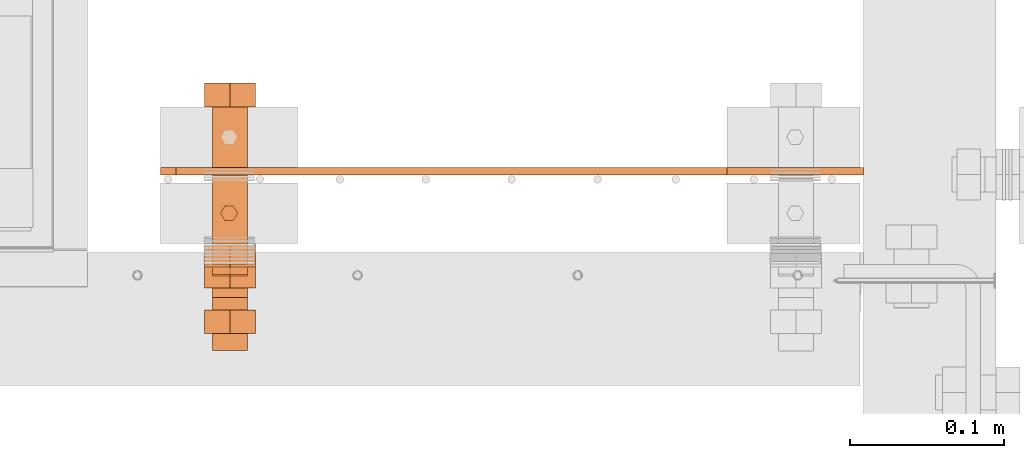
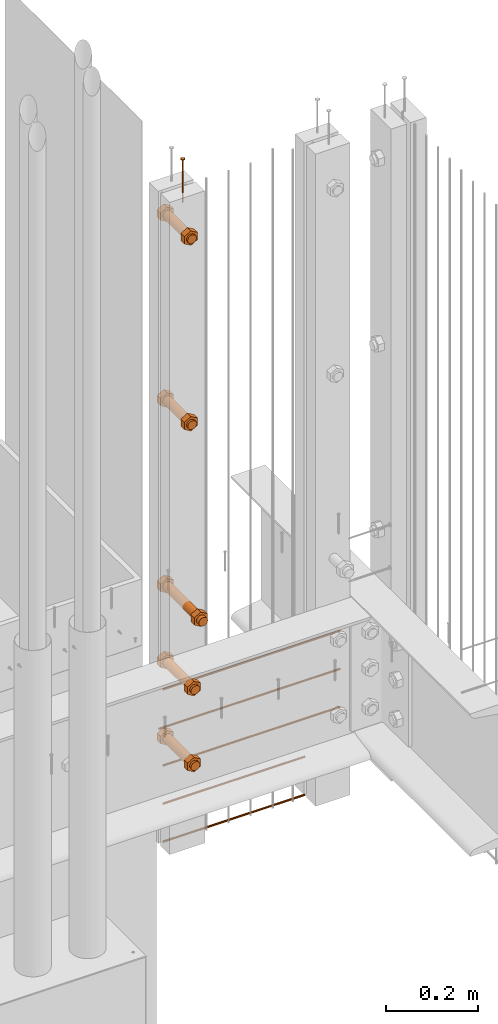
# One storey, part 20 of 44: 11 proxies.
"""IFC4 building model written with IfcOpenShell, lengths in feet."""

from ifc_helpers import new_model, entity, si_unit, converted_unit, derived_unit, direction, frame, frame_2d, origin, origin_2d_with_axis, place, context, subcontext, project, spatial, polyline, circle, outline, extrude, source, transform, mapped, material, type_object, type_shapes, element, save


model = new_model("IFC4")

# Units and contexts
model_context = context("Model", 3, precision=0.0001, world=origin(), true_north=direction((6.12303176911189e-17, 1.0)))
body_context = subcontext(model_context, "Body", "Model", "MODEL_VIEW")
ifc_project = project(units=[converted_unit("LENGTHUNIT", "FOOT", entity("IfcRatioMeasure", 0.3048), si_unit("LENGTHUNIT", "METRE"), dimensions=[1, 0, 0, 0, 0, 0, 0]), converted_unit("AREAUNIT", "SQUARE FOOT", entity("IfcRatioMeasure", 0.09290304), si_unit("AREAUNIT", "SQUARE_METRE"), dimensions=[2, 0, 0, 0, 0, 0, 0]), converted_unit("VOLUMEUNIT", "CUBIC FOOT", entity("IfcRatioMeasure", 0.028316846592), si_unit("VOLUMEUNIT", "CUBIC_METRE"), dimensions=[3, 0, 0, 0, 0, 0, 0]), converted_unit("PLANEANGLEUNIT", "DEGREE", entity("IfcRatioMeasure", 0.0174532925199433), si_unit("PLANEANGLEUNIT", "RADIAN"), dimensions=[0, 0, 0, 0, 0, 0, 0]), si_unit("MASSUNIT", "GRAM", prefix="KILO"), derived_unit("MASSDENSITYUNIT", [(si_unit("MASSUNIT", "GRAM", prefix="KILO"), 1), (si_unit("LENGTHUNIT", "METRE"), -3)]), derived_unit("MOMENTOFINERTIAUNIT", [(si_unit("LENGTHUNIT", "METRE"), 4)]), si_unit("TIMEUNIT", "SECOND"), si_unit("FREQUENCYUNIT", "HERTZ"), si_unit("THERMODYNAMICTEMPERATUREUNIT", "DEGREE_CELSIUS"), derived_unit("THERMALTRANSMITTANCEUNIT", [(si_unit("MASSUNIT", "GRAM", prefix="KILO"), 1), (si_unit("THERMODYNAMICTEMPERATUREUNIT", "KELVIN"), -1), (si_unit("TIMEUNIT", "SECOND"), -3)]), derived_unit("VOLUMETRICFLOWRATEUNIT", [(si_unit("LENGTHUNIT", "METRE"), 3), (si_unit("TIMEUNIT", "SECOND"), -1)]), si_unit("ELECTRICCURRENTUNIT", "AMPERE"), si_unit("ELECTRICVOLTAGEUNIT", "VOLT"), si_unit("POWERUNIT", "WATT"), si_unit("FORCEUNIT", "NEWTON"), si_unit("ILLUMINANCEUNIT", "LUX"), si_unit("LUMINOUSFLUXUNIT", "LUMEN"), si_unit("LUMINOUSINTENSITYUNIT", "CANDELA"), derived_unit("USERDEFINED", [(si_unit("MASSUNIT", "GRAM", prefix="KILO"), -1), (si_unit("LENGTHUNIT", "METRE"), -2), (si_unit("TIMEUNIT", "SECOND"), 3), (si_unit("LUMINOUSFLUXUNIT", "LUMEN"), 1)]), derived_unit("LINEARVELOCITYUNIT", [(si_unit("LENGTHUNIT", "METRE"), 1), (si_unit("TIMEUNIT", "SECOND"), -1)]), si_unit("PRESSUREUNIT", "PASCAL"), derived_unit("USERDEFINED", [(si_unit("LENGTHUNIT", "METRE"), -2), (si_unit("MASSUNIT", "GRAM", prefix="KILO"), 1), (si_unit("TIMEUNIT", "SECOND"), -2)]), derived_unit("LINEARFORCEUNIT", [(si_unit("MASSUNIT", "GRAM", prefix="KILO"), 1), (si_unit("LENGTHUNIT", "METRE"), 1), (si_unit("TIMEUNIT", "SECOND"), -2), (si_unit("LENGTHUNIT", "METRE"), -1)]), derived_unit("PLANARFORCEUNIT", [(si_unit("MASSUNIT", "GRAM", prefix="KILO"), 1), (si_unit("LENGTHUNIT", "METRE"), 1), (si_unit("TIMEUNIT", "SECOND"), -2), (si_unit("LENGTHUNIT", "METRE"), -2)])], contexts=[model_context])

# Site, building, storey
site_placement = place(None, origin())
site = spatial("IfcSite", under=ifc_project, at=site_placement, CompositionType="ELEMENT")
building_placement = place(site_placement, origin())
building = spatial("IfcBuilding", under=site, at=building_placement, CompositionType="ELEMENT")
storey_placement = place(building_placement, origin())
storey = spatial("IfcBuildingStorey", under=building, at=storey_placement, CompositionType="ELEMENT", Elevation=0.0)

# Proxies
ifc_material_1 = material(Category="Materials")
building_element_proxy_type_1 = type_object("IfcBuildingElementProxyType", Name="RAILING 29:RAILING 20", PredefinedType="NOTDEFINED", material=ifc_material_1)
shared_shape_1 = source(origin(), body_context, "Body", "SweptSolid", [
    extrude(circle(Radius=0.00833333333333333, at=origin_2d_with_axis()), frame((0.0, 0.0135671661283334, 0.0135671661283325), z_axis=(1.0, 0.0, 0.0), x_axis=(0.0, 1.0, 0.0)), (0.0, 0.0, 1.0), 1.17510891080246),
])
type_shapes(building_element_proxy_type_1, [shared_shape_1])
proxy_1_placement = place(storey_placement, frame((1492.54218046839, 4.89847175573906, 8.50513061952913)))
element("IfcBuildingElementProxy", 1, at=proxy_1_placement, inside=storey, type_object=building_element_proxy_type_1, material=ifc_material_1, Name="RAILING 29:RAILING 20", ObjectType="RAILING 29:RAILING 20", PredefinedType="NOTDEFINED", context=body_context, shape_type="MappedRepresentation", body=[
    mapped(shared_shape_1, transform((0.0, 0.0, 0.0), scale=1.0)),
])
building_element_proxy_type_2 = type_object("IfcBuildingElementProxyType", Name="RAILING 35:RAILING 20", PredefinedType="NOTDEFINED", material=ifc_material_1)
shared_shape_2 = source(origin(), body_context, "Body", "SweptSolid", [
    extrude(circle(Radius=0.00833333333333333, at=origin_2d_with_axis()), frame((0.0, 0.0135671661283334, 0.0135671661283325), z_axis=(1.0, 0.0, 0.0), x_axis=(0.0, 1.0, 0.0)), (0.0, 0.0, 1.0), 1.17510891080246),
])
type_shapes(building_element_proxy_type_2, [shared_shape_2])
proxy_2_placement = place(storey_placement, frame((1492.54218046839, 4.89847175573906, 8.17184950053833)))
element("IfcBuildingElementProxy", 2, at=proxy_2_placement, inside=storey, type_object=building_element_proxy_type_2, material=ifc_material_1, Name="RAILING 35:RAILING 20", ObjectType="RAILING 35:RAILING 20", PredefinedType="NOTDEFINED", context=body_context, shape_type="MappedRepresentation", body=[
    mapped(shared_shape_2, transform((0.0, 0.0, 0.0), scale=1.0)),
])
ifc_material_2 = material(Name="TRIM HEAD SCREWS AT RAILING - EXTERIOR GRADE", Category="Materials")
building_element_proxy_type_3 = type_object("IfcBuildingElementProxyType", PredefinedType="NOTDEFINED", material=ifc_material_2)
cartesian_point_1 = entity("IfcCartesianPoint", [0.0, -0.00455729166677975, -0.374999999999898])
vertex_point_1 = entity("IfcVertexPoint", cartesian_point_1)
cartesian_point_2 = entity("IfcCartesianPoint", [0.0, 0.00455729166667765, -0.374999999999898])
vertex_point_2 = entity("IfcVertexPoint", cartesian_point_2)
cartesian_point_3 = entity("IfcCartesianPoint", [0.0, 0.0, -0.374999999999898])
ifc_direction_1 = entity("IfcDirection", [0.0, 0.0, 1.0])
ifc_direction_2 = entity("IfcDirection", [0.0, 1.0, 0.0])
edge_curve_1 = entity("IfcEdgeCurve", vertex_point_1, vertex_point_2, entity("IfcTrimmedCurve", entity("IfcCircle", entity("IfcAxis2Placement3D", cartesian_point_3, ifc_direction_1, ifc_direction_2), 0.0045572916667287), [cartesian_point_1], [cartesian_point_2], True, "CARTESIAN"), True)
vertex_point_3 = entity("IfcVertexPoint", cartesian_point_3)
ifc_direction_3 = entity("IfcDirection", [0.0, -1.0, 0.0])
edge_curve_2 = entity("IfcEdgeCurve", vertex_point_2, vertex_point_3, entity("IfcTrimmedCurve", entity("IfcLine", cartesian_point_2, entity("IfcVector", ifc_direction_3, 1.0)), [cartesian_point_2], [cartesian_point_3], True, "CARTESIAN"), True)
edge_curve_3 = entity("IfcEdgeCurve", vertex_point_3, vertex_point_1, entity("IfcTrimmedCurve", entity("IfcLine", cartesian_point_3, entity("IfcVector", ifc_direction_3, 1.0)), [cartesian_point_3], [cartesian_point_1], True, "CARTESIAN"), True)
edge_curve_4 = entity("IfcEdgeCurve", vertex_point_2, vertex_point_1, entity("IfcTrimmedCurve", entity("IfcCircle", entity("IfcAxis2Placement3D", cartesian_point_3, ifc_direction_1, ifc_direction_2), 0.0045572916667287), [cartesian_point_2], [cartesian_point_1], True, "CARTESIAN"), True)
cartesian_point_4 = entity("IfcCartesianPoint", [0.0, 0.0, -0.384114583333])
vertex_point_4 = entity("IfcVertexPoint", cartesian_point_4)
edge_curve_5 = entity("IfcEdgeCurve", vertex_point_4, vertex_point_2, entity("IfcTrimmedCurve", entity("IfcLine", cartesian_point_4, entity("IfcVector", entity("IfcDirection", [0.0, 0.447213595514596, 0.894427190992597]), 1.0)), [cartesian_point_4], [cartesian_point_2], True, "CARTESIAN"), True)
edge_curve_6 = entity("IfcEdgeCurve", vertex_point_1, vertex_point_4, entity("IfcTrimmedCurve", entity("IfcLine", cartesian_point_1, entity("IfcVector", entity("IfcDirection", [0.0, 0.447213595514579, -0.894427190992605]), 1.0)), [cartesian_point_1], [cartesian_point_4], True, "CARTESIAN"), True)
cartesian_point_5 = entity("IfcCartesianPoint", [-0.00455729166669724, 0.0, -0.374999999999898])
cartesian_point_6 = entity("IfcCartesianPoint", [0.0, 0.0, -0.379868851257523])
ifc_direction_4 = entity("IfcDirection", [0.0, 0.0, -1.0])
cartesian_point_7 = entity("IfcCartesianPoint", [-0.0156249999999625, 0.00902109795594613, 0.00260416666704037])
vertex_point_5 = entity("IfcVertexPoint", cartesian_point_7)
cartesian_point_8 = entity("IfcCartesianPoint", [-0.0156249999999625, -0.0090210979562493, 0.00260416666704046])
vertex_point_6 = entity("IfcVertexPoint", cartesian_point_8)
ifc_direction_5 = entity("IfcDirection", [0.0, -1.0, 0.0])
edge_curve_7 = entity("IfcEdgeCurve", vertex_point_5, vertex_point_6, entity("IfcTrimmedCurve", entity("IfcLine", cartesian_point_7, entity("IfcVector", ifc_direction_5, 1.0)), [cartesian_point_7], [cartesian_point_8], True, "CARTESIAN"), True)
cartesian_point_9 = entity("IfcCartesianPoint", [0.0, -0.0180421959123274, 0.0026041666670405])
vertex_point_7 = entity("IfcVertexPoint", cartesian_point_9)
edge_curve_8 = entity("IfcEdgeCurve", vertex_point_6, vertex_point_7, entity("IfcTrimmedCurve", entity("IfcLine", cartesian_point_8, entity("IfcVector", entity("IfcDirection", [0.866025403784438, -0.500000000000001, 0.0]), 1.0)), [cartesian_point_8], [cartesian_point_9], True, "CARTESIAN"), True)
cartesian_point_10 = entity("IfcCartesianPoint", [0.0156250000000786, -0.00902109795620598, 0.00260416666704046])
vertex_point_8 = entity("IfcVertexPoint", cartesian_point_10)
edge_curve_9 = entity("IfcEdgeCurve", vertex_point_7, vertex_point_8, entity("IfcTrimmedCurve", entity("IfcLine", cartesian_point_9, entity("IfcVector", entity("IfcDirection", [0.86602540378444, 0.499999999999998, 0.0]), 1.0)), [cartesian_point_9], [cartesian_point_10], True, "CARTESIAN"), True)
cartesian_point_11 = entity("IfcCartesianPoint", [0.0156250000000786, 0.00902109795590273, 0.00260416666704037])
vertex_point_9 = entity("IfcVertexPoint", cartesian_point_11)
ifc_direction_6 = entity("IfcDirection", [0.0, 1.0, 0.0])
edge_curve_10 = entity("IfcEdgeCurve", vertex_point_8, vertex_point_9, entity("IfcTrimmedCurve", entity("IfcLine", cartesian_point_10, entity("IfcVector", ifc_direction_6, 1.0)), [cartesian_point_10], [cartesian_point_11], True, "CARTESIAN"), True)
cartesian_point_12 = entity("IfcCartesianPoint", [0.0, 0.0180421959120243, 0.00260416666704032])
vertex_point_10 = entity("IfcVertexPoint", cartesian_point_12)
edge_curve_11 = entity("IfcEdgeCurve", vertex_point_9, vertex_point_10, entity("IfcTrimmedCurve", entity("IfcLine", cartesian_point_11, entity("IfcVector", entity("IfcDirection", [-0.866025403784437, 0.500000000000003, 0.0]), 1.0)), [cartesian_point_11], [cartesian_point_12], True, "CARTESIAN"), True)
edge_curve_12 = entity("IfcEdgeCurve", vertex_point_10, vertex_point_5, entity("IfcTrimmedCurve", entity("IfcLine", cartesian_point_12, entity("IfcVector", entity("IfcDirection", [-0.866025403784438, -0.500000000000001, 0.0]), 1.0)), [cartesian_point_12], [cartesian_point_7], True, "CARTESIAN"), True)
ifc_direction_7 = entity("IfcDirection", [0.0, 0.0, 1.0])
cartesian_point_13 = entity("IfcCartesianPoint", [-0.0156249999999625, 0.00902109795594612, 0.0])
vertex_point_11 = entity("IfcVertexPoint", cartesian_point_13)
cartesian_point_14 = entity("IfcCartesianPoint", [0.0, 0.0180421959120242, 0.0])
vertex_point_12 = entity("IfcVertexPoint", cartesian_point_14)
edge_curve_13 = entity("IfcEdgeCurve", vertex_point_11, vertex_point_12, entity("IfcTrimmedCurve", entity("IfcLine", cartesian_point_13, entity("IfcVector", entity("IfcDirection", [0.866025403784438, 0.500000000000001, 0.0]), 1.0)), [cartesian_point_13], [cartesian_point_14], True, "CARTESIAN"), True)
cartesian_point_15 = entity("IfcCartesianPoint", [0.0156250000000786, 0.00902109795590272, 0.0])
vertex_point_13 = entity("IfcVertexPoint", cartesian_point_15)
edge_curve_14 = entity("IfcEdgeCurve", vertex_point_12, vertex_point_13, entity("IfcTrimmedCurve", entity("IfcLine", cartesian_point_14, entity("IfcVector", entity("IfcDirection", [0.866025403784437, -0.500000000000003, 0.0]), 1.0)), [cartesian_point_14], [cartesian_point_15], True, "CARTESIAN"), True)
cartesian_point_16 = entity("IfcCartesianPoint", [0.0156250000000786, -0.00902109795620599, 0.0])
vertex_point_14 = entity("IfcVertexPoint", cartesian_point_16)
edge_curve_15 = entity("IfcEdgeCurve", vertex_point_13, vertex_point_14, entity("IfcTrimmedCurve", entity("IfcLine", cartesian_point_15, entity("IfcVector", ifc_direction_5, 1.0)), [cartesian_point_15], [cartesian_point_16], True, "CARTESIAN"), True)
cartesian_point_17 = entity("IfcCartesianPoint", [0.0, -0.0180421959123274, 0.0])
vertex_point_15 = entity("IfcVertexPoint", cartesian_point_17)
edge_curve_16 = entity("IfcEdgeCurve", vertex_point_14, vertex_point_15, entity("IfcTrimmedCurve", entity("IfcLine", cartesian_point_16, entity("IfcVector", entity("IfcDirection", [-0.86602540378444, -0.499999999999998, 0.0]), 1.0)), [cartesian_point_16], [cartesian_point_17], True, "CARTESIAN"), True)
cartesian_point_18 = entity("IfcCartesianPoint", [-0.0156249999999625, -0.00902109795624931, 0.0])
vertex_point_16 = entity("IfcVertexPoint", cartesian_point_18)
edge_curve_17 = entity("IfcEdgeCurve", vertex_point_15, vertex_point_16, entity("IfcTrimmedCurve", entity("IfcLine", cartesian_point_17, entity("IfcVector", entity("IfcDirection", [-0.866025403784438, 0.500000000000001, 0.0]), 1.0)), [cartesian_point_17], [cartesian_point_18], True, "CARTESIAN"), True)
edge_curve_18 = entity("IfcEdgeCurve", vertex_point_16, vertex_point_11, entity("IfcTrimmedCurve", entity("IfcLine", cartesian_point_18, entity("IfcVector", ifc_direction_6, 1.0)), [cartesian_point_18], [cartesian_point_13], True, "CARTESIAN"), True)
ifc_direction_8 = entity("IfcDirection", [0.0, 0.0, -1.0])
edge_curve_19 = entity("IfcEdgeCurve", vertex_point_5, vertex_point_11, entity("IfcTrimmedCurve", entity("IfcLine", cartesian_point_7, entity("IfcVector", ifc_direction_8, 1.0)), [cartesian_point_7], [cartesian_point_13], True, "CARTESIAN"), True)
edge_curve_20 = entity("IfcEdgeCurve", vertex_point_16, vertex_point_6, entity("IfcTrimmedCurve", entity("IfcLine", cartesian_point_8, entity("IfcVector", ifc_direction_7, 1.0)), [cartesian_point_18], [cartesian_point_8], True, "CARTESIAN"), True)
edge_curve_21 = entity("IfcEdgeCurve", vertex_point_15, vertex_point_7, entity("IfcTrimmedCurve", entity("IfcLine", cartesian_point_9, entity("IfcVector", ifc_direction_7, 1.0)), [cartesian_point_17], [cartesian_point_9], True, "CARTESIAN"), True)
edge_curve_22 = entity("IfcEdgeCurve", vertex_point_14, vertex_point_8, entity("IfcTrimmedCurve", entity("IfcLine", cartesian_point_10, entity("IfcVector", ifc_direction_7, 1.0)), [cartesian_point_16], [cartesian_point_10], True, "CARTESIAN"), True)
edge_curve_23 = entity("IfcEdgeCurve", vertex_point_13, vertex_point_9, entity("IfcTrimmedCurve", entity("IfcLine", cartesian_point_11, entity("IfcVector", ifc_direction_7, 1.0)), [cartesian_point_15], [cartesian_point_11], True, "CARTESIAN"), True)
edge_curve_24 = entity("IfcEdgeCurve", vertex_point_12, vertex_point_10, entity("IfcTrimmedCurve", entity("IfcLine", cartesian_point_12, entity("IfcVector", ifc_direction_7, 1.0)), [cartesian_point_14], [cartesian_point_12], True, "CARTESIAN"), True)
cartesian_point_19 = entity("IfcCartesianPoint", [0.0, -0.00455729166682102, 0.0])
vertex_point_17 = entity("IfcVertexPoint", cartesian_point_19)
cartesian_point_20 = entity("IfcCartesianPoint", [0.0, 0.00455729166651231, 0.0])
vertex_point_18 = entity("IfcVertexPoint", cartesian_point_20)
cartesian_point_21 = entity("IfcCartesianPoint", [0.0, 0.0, 0.0])
ifc_direction_9 = entity("IfcDirection", [0.0, 0.0, 1.0])
ifc_direction_10 = entity("IfcDirection", [0.0, 1.0, 0.0])
edge_curve_25 = entity("IfcEdgeCurve", vertex_point_17, vertex_point_18, entity("IfcTrimmedCurve", entity("IfcCircle", entity("IfcAxis2Placement3D", cartesian_point_21, ifc_direction_9, ifc_direction_10), 0.00455729166666667), [cartesian_point_19], [cartesian_point_20], True, "CARTESIAN"), True)
edge_curve_26 = entity("IfcEdgeCurve", vertex_point_18, vertex_point_17, entity("IfcTrimmedCurve", entity("IfcCircle", entity("IfcAxis2Placement3D", cartesian_point_21, ifc_direction_9, ifc_direction_10), 0.00455729166666667), [cartesian_point_20], [cartesian_point_19], True, "CARTESIAN"), True)
cartesian_point_22 = entity("IfcCartesianPoint", [0.0, -0.00455729166682425, -0.375000000000006])
vertex_point_19 = entity("IfcVertexPoint", cartesian_point_22)
cartesian_point_23 = entity("IfcCartesianPoint", [0.0, 0.00455729166650908, -0.375000000000006])
vertex_point_20 = entity("IfcVertexPoint", cartesian_point_23)
cartesian_point_24 = entity("IfcCartesianPoint", [0.0, 0.0, -0.375000000000006])
ifc_direction_11 = entity("IfcDirection", [0.0, 0.0, -1.0])
edge_curve_27 = entity("IfcEdgeCurve", vertex_point_19, vertex_point_20, entity("IfcTrimmedCurve", entity("IfcCircle", entity("IfcAxis2Placement3D", cartesian_point_24, ifc_direction_11, ifc_direction_10), 0.00455729166666667), [cartesian_point_22], [cartesian_point_23], True, "CARTESIAN"), True)
edge_curve_28 = entity("IfcEdgeCurve", vertex_point_20, vertex_point_19, entity("IfcTrimmedCurve", entity("IfcCircle", entity("IfcAxis2Placement3D", cartesian_point_24, ifc_direction_11, ifc_direction_10), 0.00455729166666667), [cartesian_point_23], [cartesian_point_22], True, "CARTESIAN"), True)
edge_curve_29 = entity("IfcEdgeCurve", vertex_point_17, vertex_point_19, entity("IfcTrimmedCurve", entity("IfcLine", cartesian_point_19, entity("IfcVector", ifc_direction_11, 1.0)), [cartesian_point_19], [cartesian_point_22], True, "CARTESIAN"), True)
edge_curve_30 = entity("IfcEdgeCurve", vertex_point_20, vertex_point_18, entity("IfcTrimmedCurve", entity("IfcLine", cartesian_point_20, entity("IfcVector", ifc_direction_9, 1.0)), [cartesian_point_23], [cartesian_point_20], True, "CARTESIAN"), True)
shared_shape_3 = source(origin(), body_context, "Body", "AdvancedBrep", [
    entity("IfcAdvancedBrep", entity("IfcClosedShell", [entity("IfcAdvancedFace", [entity("IfcFaceOuterBound", entity("IfcEdgeLoop", [entity("IfcOrientedEdge", None, None, edge_curve_1, True), entity("IfcOrientedEdge", None, None, edge_curve_2, True), entity("IfcOrientedEdge", None, None, edge_curve_3, True)]), True)], entity("IfcPlane", entity("IfcAxis2Placement3D", cartesian_point_3, ifc_direction_1, ifc_direction_2)), True), entity("IfcAdvancedFace", [entity("IfcFaceOuterBound", entity("IfcEdgeLoop", [entity("IfcOrientedEdge", None, None, edge_curve_4, True), entity("IfcOrientedEdge", None, None, edge_curve_3, False), entity("IfcOrientedEdge", None, None, edge_curve_2, False)]), True)], entity("IfcPlane", entity("IfcAxis2Placement3D", cartesian_point_3, ifc_direction_1, ifc_direction_2)), True), entity("IfcAdvancedFace", [entity("IfcFaceOuterBound", entity("IfcEdgeLoop", [entity("IfcOrientedEdge", None, None, edge_curve_5, True), entity("IfcOrientedEdge", None, None, edge_curve_1, False), entity("IfcOrientedEdge", None, None, edge_curve_6, True)]), True)], entity("IfcSurfaceOfRevolution", entity("IfcArbitraryOpenProfileDef", "CURVE", None, entity("IfcTrimmedCurve", entity("IfcLine", cartesian_point_4, entity("IfcVector", entity("IfcDirection", [0.447213595514577, 0.0, -0.894427190992606]), 1.0)), [cartesian_point_5], [cartesian_point_4], True, "CARTESIAN")), None, entity("IfcAxis1Placement", cartesian_point_6, ifc_direction_4)), True), entity("IfcAdvancedFace", [entity("IfcFaceOuterBound", entity("IfcEdgeLoop", [entity("IfcOrientedEdge", None, None, edge_curve_6, False), entity("IfcOrientedEdge", None, None, edge_curve_4, False), entity("IfcOrientedEdge", None, None, edge_curve_5, False)]), True)], entity("IfcSurfaceOfRevolution", entity("IfcArbitraryOpenProfileDef", "CURVE", None, entity("IfcTrimmedCurve", entity("IfcLine", cartesian_point_4, entity("IfcVector", entity("IfcDirection", [0.447213595514577, 0.0, -0.894427190992606]), 1.0)), [cartesian_point_5], [cartesian_point_4], True, "CARTESIAN")), None, entity("IfcAxis1Placement", cartesian_point_6, ifc_direction_4)), True)])),
    entity("IfcAdvancedBrep", entity("IfcClosedShell", [entity("IfcAdvancedFace", [entity("IfcFaceOuterBound", entity("IfcEdgeLoop", [entity("IfcOrientedEdge", None, None, edge_curve_7, True), entity("IfcOrientedEdge", None, None, edge_curve_8, True), entity("IfcOrientedEdge", None, None, edge_curve_9, True), entity("IfcOrientedEdge", None, None, edge_curve_10, True), entity("IfcOrientedEdge", None, None, edge_curve_11, True), entity("IfcOrientedEdge", None, None, edge_curve_12, True)]), True)], entity("IfcPlane", entity("IfcAxis2Placement3D", cartesian_point_7, ifc_direction_7, ifc_direction_5)), True), entity("IfcAdvancedFace", [entity("IfcFaceOuterBound", entity("IfcEdgeLoop", [entity("IfcOrientedEdge", None, None, edge_curve_13, True), entity("IfcOrientedEdge", None, None, edge_curve_14, True), entity("IfcOrientedEdge", None, None, edge_curve_15, True), entity("IfcOrientedEdge", None, None, edge_curve_16, True), entity("IfcOrientedEdge", None, None, edge_curve_17, True), entity("IfcOrientedEdge", None, None, edge_curve_18, True)]), True)], entity("IfcPlane", entity("IfcAxis2Placement3D", cartesian_point_13, ifc_direction_8, ifc_direction_6)), True), entity("IfcAdvancedFace", [entity("IfcFaceOuterBound", entity("IfcEdgeLoop", [entity("IfcOrientedEdge", None, None, edge_curve_7, False), entity("IfcOrientedEdge", None, None, edge_curve_19, True), entity("IfcOrientedEdge", None, None, edge_curve_18, False), entity("IfcOrientedEdge", None, None, edge_curve_20, True)]), True)], entity("IfcPlane", entity("IfcAxis2Placement3D", cartesian_point_7, entity("IfcDirection", [-1.0, 0.0, 0.0]), ifc_direction_8)), True), entity("IfcAdvancedFace", [entity("IfcFaceOuterBound", entity("IfcEdgeLoop", [entity("IfcOrientedEdge", None, None, edge_curve_8, False), entity("IfcOrientedEdge", None, None, edge_curve_20, False), entity("IfcOrientedEdge", None, None, edge_curve_17, False), entity("IfcOrientedEdge", None, None, edge_curve_21, True)]), True)], entity("IfcPlane", entity("IfcAxis2Placement3D", cartesian_point_8, entity("IfcDirection", [-0.500000000000001, -0.866025403784438, 0.0]), ifc_direction_8)), True), entity("IfcAdvancedFace", [entity("IfcFaceOuterBound", entity("IfcEdgeLoop", [entity("IfcOrientedEdge", None, None, edge_curve_9, False), entity("IfcOrientedEdge", None, None, edge_curve_21, False), entity("IfcOrientedEdge", None, None, edge_curve_16, False), entity("IfcOrientedEdge", None, None, edge_curve_22, True)]), True)], entity("IfcPlane", entity("IfcAxis2Placement3D", cartesian_point_9, entity("IfcDirection", [0.499999999999998, -0.86602540378444, 0.0]), ifc_direction_8)), True), entity("IfcAdvancedFace", [entity("IfcFaceOuterBound", entity("IfcEdgeLoop", [entity("IfcOrientedEdge", None, None, edge_curve_10, False), entity("IfcOrientedEdge", None, None, edge_curve_22, False), entity("IfcOrientedEdge", None, None, edge_curve_15, False), entity("IfcOrientedEdge", None, None, edge_curve_23, True)]), True)], entity("IfcPlane", entity("IfcAxis2Placement3D", cartesian_point_10, entity("IfcDirection", [1.0, 0.0, 0.0]), ifc_direction_8)), True), entity("IfcAdvancedFace", [entity("IfcFaceOuterBound", entity("IfcEdgeLoop", [entity("IfcOrientedEdge", None, None, edge_curve_11, False), entity("IfcOrientedEdge", None, None, edge_curve_23, False), entity("IfcOrientedEdge", None, None, edge_curve_14, False), entity("IfcOrientedEdge", None, None, edge_curve_24, True)]), True)], entity("IfcPlane", entity("IfcAxis2Placement3D", cartesian_point_11, entity("IfcDirection", [0.500000000000003, 0.866025403784437, 0.0]), ifc_direction_8)), True), entity("IfcAdvancedFace", [entity("IfcFaceOuterBound", entity("IfcEdgeLoop", [entity("IfcOrientedEdge", None, None, edge_curve_12, False), entity("IfcOrientedEdge", None, None, edge_curve_24, False), entity("IfcOrientedEdge", None, None, edge_curve_13, False), entity("IfcOrientedEdge", None, None, edge_curve_19, False)]), True)], entity("IfcPlane", entity("IfcAxis2Placement3D", cartesian_point_12, entity("IfcDirection", [-0.500000000000001, 0.866025403784438, 0.0]), ifc_direction_8)), True)])),
    entity("IfcAdvancedBrep", entity("IfcClosedShell", [entity("IfcAdvancedFace", [entity("IfcFaceOuterBound", entity("IfcEdgeLoop", [entity("IfcOrientedEdge", None, None, edge_curve_25, True), entity("IfcOrientedEdge", None, None, edge_curve_26, True)]), True)], entity("IfcPlane", entity("IfcAxis2Placement3D", cartesian_point_20, ifc_direction_9, entity("IfcDirection", [-1.0, 0.0, 0.0]))), True), entity("IfcAdvancedFace", [entity("IfcFaceOuterBound", entity("IfcEdgeLoop", [entity("IfcOrientedEdge", None, None, edge_curve_27, True), entity("IfcOrientedEdge", None, None, edge_curve_28, True)]), True)], entity("IfcPlane", entity("IfcAxis2Placement3D", cartesian_point_23, ifc_direction_11, entity("IfcDirection", [1.0, 0.0, 0.0]))), True), entity("IfcAdvancedFace", [entity("IfcFaceOuterBound", entity("IfcEdgeLoop", [entity("IfcOrientedEdge", None, None, edge_curve_25, False), entity("IfcOrientedEdge", None, None, edge_curve_29, True), entity("IfcOrientedEdge", None, None, edge_curve_28, False), entity("IfcOrientedEdge", None, None, edge_curve_30, True)]), True)], entity("IfcCylindricalSurface", entity("IfcAxis2Placement3D", cartesian_point_24, ifc_direction_9, ifc_direction_10), 0.00455729166666667), True), entity("IfcAdvancedFace", [entity("IfcFaceOuterBound", entity("IfcEdgeLoop", [entity("IfcOrientedEdge", None, None, edge_curve_26, False), entity("IfcOrientedEdge", None, None, edge_curve_30, False), entity("IfcOrientedEdge", None, None, edge_curve_27, False), entity("IfcOrientedEdge", None, None, edge_curve_29, False)]), True)], entity("IfcCylindricalSurface", entity("IfcAxis2Placement3D", cartesian_point_24, ifc_direction_9, ifc_direction_10), 0.00455729166666667), True)])),
])
type_shapes(building_element_proxy_type_3, [shared_shape_3])
proxy_3_placement = place(storey_placement, frame((1492.65505560864, 4.82245558853414, 14.1770833333334), z_axis=(0.0, 0.0, 1.0), x_axis=(0.0, -1.0, 0.0)))
element("IfcBuildingElementProxy", 3, at=proxy_3_placement, inside=storey, type_object=building_element_proxy_type_3, material=ifc_material_2, PredefinedType="NOTDEFINED", context=body_context, shape_type="MappedRepresentation", body=[
    mapped(shared_shape_3, transform((0.0, 0.0, 0.0), scale=1.0)),
])
ifc_material_3 = material(Name="EXPOSED LAG BOLTS", Category="Materials")
building_element_proxy_type_4 = type_object("IfcBuildingElementProxyType", PredefinedType="NOTDEFINED", material=ifc_material_3)
shared_shape_4 = source(origin(), body_context, "Body", "SweptSolid", [
    extrude(outline(polyline([(-0.0315738428463097, -0.0546875000000126), (0.0315738428462861, -0.0546875000000126), (0.0631476856926272, 0.0), (0.0315738428463528, 0.0546874999999876), (-0.0315738428463294, 0.0546874999999873), (-0.0631476856926271, 0.0), (-0.0315738428463097, -0.0546875000000126)])), frame((0.0, 0.0, -0.386942113267977), z_axis=(0.0, 0.0, 1.0), x_axis=(0.866025403784438, -0.500000000000001, 0.0)), (0.0, 0.0, 1.0), 0.0504557291666657),
    extrude(outline(polyline([(-0.0315738428463175, -0.054687500000008), (0.0315738428463173, -0.054687500000008), (0.0631476856926152, 0.0), (0.0315738428462743, 0.0546875000000329), (-0.0315738428462739, 0.0546875000000332), (-0.0631476856926154, 0.0), (-0.0315738428463175, -0.054687500000008)])), frame((0.0, 0.0, 0.0), z_axis=(0.0, 0.0, 1.0), x_axis=(0.0, -1.0, 0.0)), (0.0, 0.0, 1.0), 0.0504557291666658),
    extrude(circle(Radius=0.0372721354166667, at=frame_2d((-2.80951618260646e-18, -6.0214796149918e-17), x_axis=(1.0, 0.0))), frame((0.0, 0.0, -0.407332794173276), z_axis=(0.0, 0.0, 1.0), x_axis=(0.0, 1.0, 0.0)), (0.0, 0.0, 1.0), 0.40733279417327),
])
type_shapes(building_element_proxy_type_4, [shared_shape_4])
for number, where, z_axis, x_axis in (
    (4, (1492.65687271252, 5.04953892186732, 9.63648022547445), (0.0, 1.0, 0.0), (-1.0, 0.0, 0.0)),
    (5, (1492.65687271252, 5.04953892186732, 8.97060028623032), (0.0, 1.0, 0.0), (-1.0, 0.0, 0.0)),
):
    element("IfcBuildingElementProxy", number, at=place(storey_placement, frame(where, z_axis=z_axis, x_axis=x_axis)), inside=storey, type_object=building_element_proxy_type_4, material=ifc_material_3, PredefinedType="NOTDEFINED", context=body_context, shape_type="MappedRepresentation", body=[
        mapped(shared_shape_4, transform((0.0, 0.0, 0.0), scale=1.0)),
    ])
building_element_proxy_type_5 = type_object("IfcBuildingElementProxyType", PredefinedType="NOTDEFINED", material=ifc_material_3)
shared_shape_5 = source(origin(), body_context, "Body", "SweptSolid", [
    extrude(outline(polyline([(-0.0315738428463097, -0.0546875000000126), (0.0315738428462861, -0.0546875000000126), (0.0631476856926272, 0.0), (0.0315738428463528, 0.0546874999999876), (-0.0315738428463294, 0.0546874999999873), (-0.0631476856926271, 0.0), (-0.0315738428463097, -0.0546875000000126)])), frame((0.0, 0.0, -0.484242878785973), z_axis=(0.0, 0.0, 1.0), x_axis=(0.866025403784438, -0.500000000000001, 0.0)), (0.0, 0.0, 1.0), 0.0504557291666657),
    extrude(outline(polyline([(-0.0315738428463175, -0.054687500000008), (0.0315738428463173, -0.054687500000008), (0.0631476856926152, 0.0), (0.0315738428462743, 0.0546875000000329), (-0.0315738428462739, 0.0546875000000332), (-0.0631476856926154, 0.0), (-0.0315738428463175, -0.054687500000008)])), frame((0.0, 0.0, 0.0), z_axis=(0.0, 0.0, 1.0), x_axis=(0.0, -1.0, 0.0)), (0.0, 0.0, 1.0), 0.0504557291666658),
    extrude(circle(Radius=0.0372721354166667, at=frame_2d((-1.22784132337394e-18, -6.0214796149918e-17), x_axis=(1.0, 0.0))), frame((0.0, 0.0, -0.519932766939084), z_axis=(0.0, 0.0, 1.0), x_axis=(0.0, 1.0, 0.0)), (0.0, 0.0, 1.0), 0.519932766939078),
])
type_shapes(building_element_proxy_type_5, [shared_shape_5])
proxy_4_placement = place(storey_placement, frame((1492.65687271252, 5.04953892186733, 10.3023927658464), z_axis=(0.0, 1.0, 0.0), x_axis=(-1.0, 0.0, 0.0)))
element("IfcBuildingElementProxy", 6, at=proxy_4_placement, inside=storey, type_object=building_element_proxy_type_5, material=ifc_material_3, PredefinedType="NOTDEFINED", context=body_context, shape_type="MappedRepresentation", body=[
    mapped(shared_shape_5, transform((0.0, 0.0, 0.0), scale=1.0)),
])
building_element_proxy_type_6 = type_object("IfcBuildingElementProxyType", Name="RAILING 50:RAILING 20", PredefinedType="NOTDEFINED", material=ifc_material_1)
shared_shape_6 = source(origin(), body_context, "Body", "SweptSolid", [
    extrude(circle(Radius=0.00833333333333333, at=origin_2d_with_axis()), frame((0.0, 0.0135671661283334, 0.0135671661283325), z_axis=(1.0, 0.0, 0.0), x_axis=(0.0, 1.0, 0.0)), (0.0, 0.0, 1.0), 1.46677557746921),
])
type_shapes(building_element_proxy_type_6, [shared_shape_6])
proxy_5_placement = place(storey_placement, frame((1492.54218046839, 4.89847175573906, 9.50518283387163)))
element("IfcBuildingElementProxy", 7, at=proxy_5_placement, inside=storey, type_object=building_element_proxy_type_6, material=ifc_material_1, Name="RAILING 50:RAILING 20", ObjectType="RAILING 50:RAILING 20", PredefinedType="NOTDEFINED", context=body_context, shape_type="MappedRepresentation", body=[
    mapped(shared_shape_6, transform((0.0, 0.0, 0.0), scale=1.0)),
])
building_element_proxy_type_7 = type_object("IfcBuildingElementProxyType", Name="RAILING 58:RAILING 20", PredefinedType="NOTDEFINED", material=ifc_material_1)
shared_shape_7 = source(origin(), body_context, "Body", "SweptSolid", [
    extrude(circle(Radius=0.00833333333333333, at=origin_2d_with_axis()), frame((0.0, 0.0135671661283334, 0.0135671661283325), z_axis=(1.0, 0.0, 0.0), x_axis=(0.0, 1.0, 0.0)), (0.0, 0.0, 1.0), 1.50014849154331),
])
type_shapes(building_element_proxy_type_7, [shared_shape_7])
proxy_6_placement = place(storey_placement, frame((1492.50880755431, 4.89847175573906, 9.1718495005383)))
element("IfcBuildingElementProxy", 8, at=proxy_6_placement, inside=storey, type_object=building_element_proxy_type_7, material=ifc_material_1, Name="RAILING 58:RAILING 20", ObjectType="RAILING 58:RAILING 20", PredefinedType="NOTDEFINED", context=body_context, shape_type="MappedRepresentation", body=[
    mapped(shared_shape_7, transform((0.0, 0.0, 0.0), scale=1.0)),
])
building_element_proxy_type_8 = type_object("IfcBuildingElementProxyType", Name="RAILING 59:RAILING 20", PredefinedType="NOTDEFINED", material=ifc_material_1)
shared_shape_8 = source(origin(), body_context, "Body", "SweptSolid", [
    extrude(circle(Radius=0.00833333333333333, at=origin_2d_with_axis()), frame((0.0, 0.0135671661283334, 0.0135671661283325), z_axis=(1.0, 0.0, 0.0), x_axis=(0.0, 1.0, 0.0)), (0.0, 0.0, 1.0), 1.46677557746921),
])
type_shapes(building_element_proxy_type_8, [shared_shape_8])
proxy_7_placement = place(storey_placement, frame((1492.54218046839, 4.89847175573906, 8.83851616720497)))
element("IfcBuildingElementProxy", 9, at=proxy_7_placement, inside=storey, type_object=building_element_proxy_type_8, material=ifc_material_1, Name="RAILING 59:RAILING 20", ObjectType="RAILING 59:RAILING 20", PredefinedType="NOTDEFINED", context=body_context, shape_type="MappedRepresentation", body=[
    mapped(shared_shape_8, transform((0.0, 0.0, 0.0), scale=1.0)),
])
building_element_proxy_type_9 = type_object("IfcBuildingElementProxyType", PredefinedType="NOTDEFINED", material=ifc_material_3)
shared_shape_9 = source(origin(), body_context, "Body", "SweptSolid", [
    extrude(outline(polyline([(-0.0315738428463097, -0.0546875000000126), (0.0315738428462861, -0.0546875000000126), (0.0631476856926272, 0.0), (0.0315738428463528, 0.0546874999999876), (-0.0315738428463294, 0.0546874999999873), (-0.0631476856926271, 0.0), (-0.0315738428463097, -0.0546875000000126)])), frame((0.0, 0.0, -0.342122395833737), z_axis=(0.0, 0.0, 1.0), x_axis=(0.866025403784438, -0.500000000000001, 0.0)), (0.0, 0.0, 1.0), 0.0504557291666657),
    extrude(outline(polyline([(-0.0315738428463175, -0.054687500000008), (0.0315738428463173, -0.054687500000008), (0.0631476856926152, 0.0), (0.0315738428462743, 0.0546875000000329), (-0.0315738428462739, 0.0546875000000332), (-0.0631476856926154, 0.0), (-0.0315738428463175, -0.054687500000008)])), frame((0.0, 0.0, 0.0), z_axis=(0.0, 0.0, 1.0), x_axis=(0.0, -1.0, 0.0)), (0.0, 0.0, 1.0), 0.0504557291666658),
    extrude(circle(Radius=0.0372721354166667, at=frame_2d((-2.70657840892615e-19, -6.0214796149918e-17), x_axis=(1.0, 0.0))), frame((0.0, 0.0, -0.36111899731318), z_axis=(0.0, 0.0, 1.0), x_axis=(0.0, 1.0, 0.0)), (0.0, 0.0, 1.0), 0.361118997313174),
])
type_shapes(building_element_proxy_type_9, [shared_shape_9])
proxy_8_placement = place(storey_placement, frame((1492.65687271252, 5.04953892186733, 11.92723804959), z_axis=(0.0, 1.0, 0.0), x_axis=(-1.0, 0.0, 0.0)))
element("IfcBuildingElementProxy", 10, at=proxy_8_placement, inside=storey, type_object=building_element_proxy_type_9, material=ifc_material_3, PredefinedType="NOTDEFINED", context=body_context, shape_type="MappedRepresentation", body=[
    mapped(shared_shape_9, transform((0.0, 0.0, 0.0), scale=1.0)),
])
building_element_proxy_type_10 = type_object("IfcBuildingElementProxyType", PredefinedType="NOTDEFINED", material=ifc_material_3)
shared_shape_10 = source(origin(), body_context, "Body", "SweptSolid", [
    extrude(outline(polyline([(-0.0315738428463097, -0.0546875000000126), (0.0315738428462861, -0.0546875000000126), (0.0631476856926272, 0.0), (0.0315738428463528, 0.0546874999999876), (-0.0315738428463294, 0.0546874999999873), (-0.0631476856926271, 0.0), (-0.0315738428463097, -0.0546875000000126)])), frame((0.0, 0.0, -0.342122395833722), z_axis=(0.0, 0.0, 1.0), x_axis=(0.866025403784438, -0.500000000000001, 0.0)), (0.0, 0.0, 1.0), 0.0504557291666657),
    extrude(outline(polyline([(-0.0315738428463175, -0.054687500000008), (0.0315738428463173, -0.054687500000008), (0.0631476856926152, 0.0), (0.0315738428462743, 0.0546875000000329), (-0.0315738428462739, 0.0546875000000332), (-0.0631476856926154, 0.0), (-0.0315738428463175, -0.054687500000008)])), frame((0.0, 0.0, 0.0), z_axis=(0.0, 0.0, 1.0), x_axis=(0.0, -1.0, 0.0)), (0.0, 0.0, 1.0), 0.0504557291666658),
    extrude(circle(Radius=0.0372721354166667, at=frame_2d((3.24223481772345e-18, -6.0214796149918e-17), x_axis=(1.0, 0.0))), frame((0.0, 0.0, -0.358294363236862), z_axis=(0.0, 0.0, 1.0), x_axis=(0.0, 1.0, 0.0)), (0.0, 0.0, 1.0), 0.358294363236856),
])
type_shapes(building_element_proxy_type_10, [shared_shape_10])
proxy_9_placement = place(storey_placement, frame((1492.65687271252, 5.04953892186732, 13.5520833333335), z_axis=(0.0, 1.0, 0.0), x_axis=(-1.0, 0.0, 0.0)))
element("IfcBuildingElementProxy", 11, at=proxy_9_placement, inside=storey, type_object=building_element_proxy_type_10, material=ifc_material_3, PredefinedType="NOTDEFINED", context=body_context, shape_type="MappedRepresentation", body=[
    mapped(shared_shape_10, transform((0.0, 0.0, 0.0), scale=1.0)),
])

save(model, "model.ifc")
